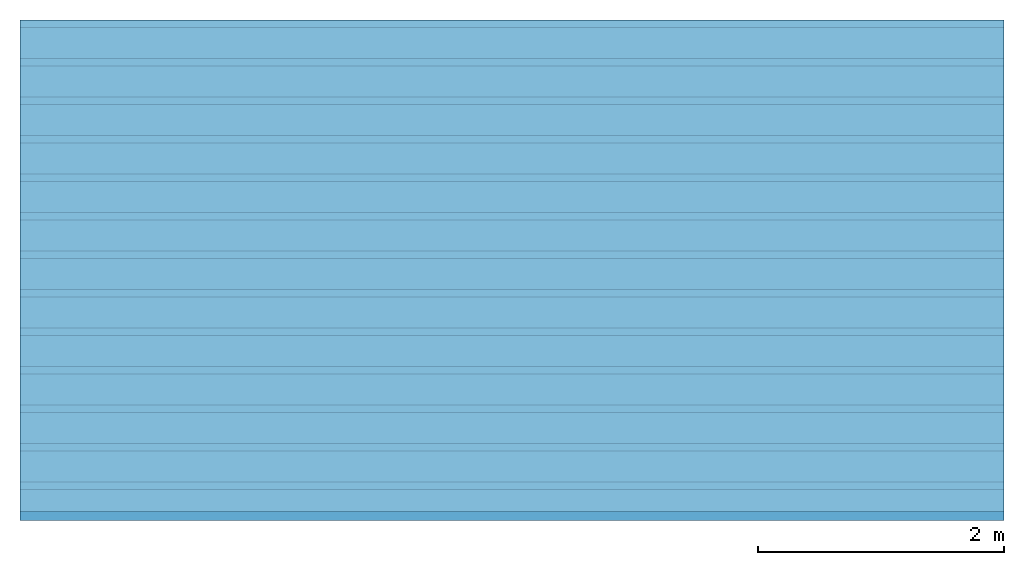
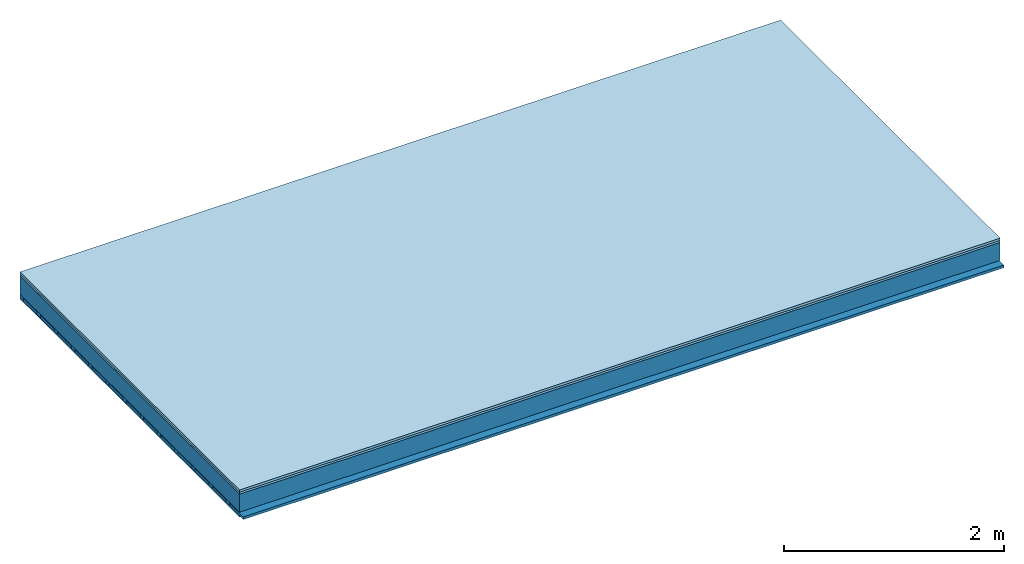
# One storey: 3 members, 3 plates, 1 element without a shape of its own.
"""IFC4 building model written with IfcOpenShell, lengths in metres."""

from ifc_helpers import new_model, si_unit, derived_unit, direction, frame, frame_2d, origin, origin_with_axes, place, context, project, spatial, rectangle, extrude, material, layer, layer_set, type_object, element, aggregate, save


model = new_model("IFC4")

# Units and contexts
plan_context = context("Plan", 3, precision=1e-05, world=origin(), true_north=direction((0.0, 1.0)))
model_context = context("Model", 3, precision=1e-05, world=origin(), true_north=direction((0.0, 1.0)))
ifc_project = project(units=[si_unit("LENGTHUNIT", "METRE"), derived_unit("SOUNDPRESSUREUNIT", [(si_unit("PRESSUREUNIT", "PASCAL", prefix="MICRO"), 0)]), si_unit("ENERGYUNIT", "JOULE", prefix="MEGA"), si_unit("MASSUNIT", "GRAM", prefix="KILO"), derived_unit("THERMALTRANSMITTANCEUNIT", [(si_unit("POWERUNIT", "WATT"), 1), (si_unit("AREAUNIT", "SQUARE_METRE"), -1), (si_unit("THERMODYNAMICTEMPERATUREUNIT", "KELVIN"), -1)]), derived_unit("AREADENSITYUNIT", [(si_unit("MASSUNIT", "GRAM", prefix="KILO"), 1), (si_unit("AREAUNIT", "SQUARE_METRE"), -1)]), derived_unit("USERDEFINED", [(si_unit("ENERGYUNIT", "JOULE", prefix="MEGA"), 1), (si_unit("AREAUNIT", "SQUARE_METRE"), -1)])], contexts=[plan_context, model_context])

# Site, building, storey
site = spatial("IfcSite", under=ifc_project)
building_placement = place(None, origin())
building = spatial("IfcBuilding", under=site, at=building_placement)
storey_placement = place(building_placement, origin())
storey = spatial("IfcBuildingStorey", under=building, at=storey_placement)

# Slab, members, plates
ifc_material_1 = material(Name="Floor heating system Therm38 longitudinal", Category="03.007")
ifc_layer_1 = layer(ifc_material_1, 0.025, Name="On-material")
ifc_material_2 = material(Category="10.009")
ifc_layer_2 = layer(ifc_material_2, 0.022, Name="Impact sound insulation")
ifc_layer_3 = layer(None, 0.2, Name="Supporting structure")
ifc_material_3 = material(Name="of the art")
ifc_layer_4 = layer(ifc_material_3, 0.0, Name="Bond")
ifc_layer_5 = layer(None, 0.04, Name="Battens / profiles")
ifc_material_4 = material(Category="03.007")
ifc_layer_6 = layer(ifc_material_4, 0.015, Name="Ceiling covering 1st layer")
ifc_material_5 = material(Name="Glued joints")
ifc_layer_7 = layer(ifc_material_5, 0.0, Name="Surface / treatment")
ifc_layer_set = layer_set([ifc_layer_1, ifc_layer_2, ifc_layer_3, ifc_layer_4, ifc_layer_5, ifc_layer_6, ifc_layer_7])
slab_type = type_object("IfcSlabType", Name="A0851", PredefinedType="NOTDEFINED", material=ifc_layer_set)
slab_placement = place(None, frame((0.0, 0.0, 0.0), z_axis=(0.0, 0.0, -1.0), x_axis=(1.0, 0.0, 0.0)))
slab = element("IfcSlab", 1, at=slab_placement, inside=storey, type_object=slab_type, material=ifc_layer_set, Name="Slab #1")
ifc_material_6 = material()
member_1_placement = place(slab_placement, origin())
member_1 = element("IfcMember", 2, at=member_1_placement, material=ifc_material_6, Name="Supporting structure", context=plan_context, shape_type="SweptSolid", body=[
    extrude(rectangle(XDim=1.0, YDim=0.2, at=frame_2d((0.5, 0.1), x_axis=(1.0, 0.0))), frame((0.0, 4.0, 0.047), z_axis=(0.0, -1.0, 0.0), x_axis=(1.0, 0.0, 0.0)), (0.0, 0.0, 1.0), 4.0),
    extrude(rectangle(XDim=1.0, YDim=0.2, at=frame_2d((0.5, 0.1), x_axis=(1.0, 0.0))), frame((1.0, 4.0, 0.047), z_axis=(0.0, -1.0, 0.0), x_axis=(1.0, 0.0, 0.0)), (0.0, 0.0, 1.0), 4.0),
    extrude(rectangle(XDim=1.0, YDim=0.2, at=frame_2d((0.5, 0.1), x_axis=(1.0, 0.0))), frame((2.0, 4.0, 0.047), z_axis=(0.0, -1.0, 0.0), x_axis=(1.0, 0.0, 0.0)), (0.0, 0.0, 1.0), 4.0),
    extrude(rectangle(XDim=1.0, YDim=0.2, at=frame_2d((0.5, 0.1), x_axis=(1.0, 0.0))), frame((3.0, 4.0, 0.047), z_axis=(0.0, -1.0, 0.0), x_axis=(1.0, 0.0, 0.0)), (0.0, 0.0, 1.0), 4.0),
    extrude(rectangle(XDim=1.0, YDim=0.2, at=frame_2d((0.5, 0.1), x_axis=(1.0, 0.0))), frame((4.0, 4.0, 0.047), z_axis=(0.0, -1.0, 0.0), x_axis=(1.0, 0.0, 0.0)), (0.0, 0.0, 1.0), 4.0),
    extrude(rectangle(XDim=1.0, YDim=0.2, at=frame_2d((0.5, 0.1), x_axis=(1.0, 0.0))), frame((5.0, 4.0, 0.047), z_axis=(0.0, -1.0, 0.0), x_axis=(1.0, 0.0, 0.0)), (0.0, 0.0, 1.0), 4.0),
    extrude(rectangle(XDim=1.0, YDim=0.2, at=frame_2d((0.5, 0.1), x_axis=(1.0, 0.0))), frame((6.0, 4.0, 0.047), z_axis=(0.0, -1.0, 0.0), x_axis=(1.0, 0.0, 0.0)), (0.0, 0.0, 1.0), 4.0),
    extrude(rectangle(XDim=1.0, YDim=0.2, at=frame_2d((0.5, 0.1), x_axis=(1.0, 0.0))), frame((7.0, 4.0, 0.047), z_axis=(0.0, -1.0, 0.0), x_axis=(1.0, 0.0, 0.0)), (0.0, 0.0, 1.0), 4.0),
])
ifc_material_7 = material()
member_2_placement = place(slab_placement, origin())
member_2 = element("IfcMember", 3, at=member_2_placement, material=ifc_material_7, Name="Battens / profiles", context=plan_context, shape_type="SweptSolid", body=[
    extrude(rectangle(XDim=0.06, YDim=0.04, at=frame_2d((0.03, 0.02), x_axis=(1.0, 0.0))), frame((0.0, 0.0, 0.247), z_axis=(1.0, 0.0, 0.0), x_axis=(0.0, 1.0, 0.0)), (0.0, 0.0, 1.0), 8.0),
    extrude(rectangle(XDim=0.06, YDim=0.04, at=frame_2d((0.03, 0.02), x_axis=(1.0, 0.0))), frame((0.0, 0.313, 0.247), z_axis=(1.0, 0.0, 0.0), x_axis=(0.0, 1.0, 0.0)), (0.0, 0.0, 1.0), 8.0),
    extrude(rectangle(XDim=0.06, YDim=0.04, at=frame_2d((0.03, 0.02), x_axis=(1.0, 0.0))), frame((0.0, 0.626, 0.247), z_axis=(1.0, 0.0, 0.0), x_axis=(0.0, 1.0, 0.0)), (0.0, 0.0, 1.0), 8.0),
    extrude(rectangle(XDim=0.06, YDim=0.04, at=frame_2d((0.03, 0.02), x_axis=(1.0, 0.0))), frame((0.0, 0.939, 0.247), z_axis=(1.0, 0.0, 0.0), x_axis=(0.0, 1.0, 0.0)), (0.0, 0.0, 1.0), 8.0),
    extrude(rectangle(XDim=0.06, YDim=0.04, at=frame_2d((0.03, 0.02), x_axis=(1.0, 0.0))), frame((0.0, 1.252, 0.247), z_axis=(1.0, 0.0, 0.0), x_axis=(0.0, 1.0, 0.0)), (0.0, 0.0, 1.0), 8.0),
    extrude(rectangle(XDim=0.06, YDim=0.04, at=frame_2d((0.03, 0.02), x_axis=(1.0, 0.0))), frame((0.0, 1.565, 0.247), z_axis=(1.0, 0.0, 0.0), x_axis=(0.0, 1.0, 0.0)), (0.0, 0.0, 1.0), 8.0),
    extrude(rectangle(XDim=0.06, YDim=0.04, at=frame_2d((0.03, 0.02), x_axis=(1.0, 0.0))), frame((0.0, 1.878, 0.247), z_axis=(1.0, 0.0, 0.0), x_axis=(0.0, 1.0, 0.0)), (0.0, 0.0, 1.0), 8.0),
    extrude(rectangle(XDim=0.06, YDim=0.04, at=frame_2d((0.03, 0.02), x_axis=(1.0, 0.0))), frame((0.0, 2.191, 0.247), z_axis=(1.0, 0.0, 0.0), x_axis=(0.0, 1.0, 0.0)), (0.0, 0.0, 1.0), 8.0),
    extrude(rectangle(XDim=0.06, YDim=0.04, at=frame_2d((0.03, 0.02), x_axis=(1.0, 0.0))), frame((0.0, 2.504, 0.247), z_axis=(1.0, 0.0, 0.0), x_axis=(0.0, 1.0, 0.0)), (0.0, 0.0, 1.0), 8.0),
    extrude(rectangle(XDim=0.06, YDim=0.04, at=frame_2d((0.03, 0.02), x_axis=(1.0, 0.0))), frame((0.0, 2.817, 0.247), z_axis=(1.0, 0.0, 0.0), x_axis=(0.0, 1.0, 0.0)), (0.0, 0.0, 1.0), 8.0),
    extrude(rectangle(XDim=0.06, YDim=0.04, at=frame_2d((0.03, 0.02), x_axis=(1.0, 0.0))), frame((0.0, 3.13, 0.247), z_axis=(1.0, 0.0, 0.0), x_axis=(0.0, 1.0, 0.0)), (0.0, 0.0, 1.0), 8.0),
    extrude(rectangle(XDim=0.06, YDim=0.04, at=frame_2d((0.03, 0.02), x_axis=(1.0, 0.0))), frame((0.0, 3.443, 0.247), z_axis=(1.0, 0.0, 0.0), x_axis=(0.0, 1.0, 0.0)), (0.0, 0.0, 1.0), 8.0),
    extrude(rectangle(XDim=0.06, YDim=0.04, at=frame_2d((0.03, 0.02), x_axis=(1.0, 0.0))), frame((0.0, 3.756, 0.247), z_axis=(1.0, 0.0, 0.0), x_axis=(0.0, 1.0, 0.0)), (0.0, 0.0, 1.0), 8.0),
])
ifc_material_8 = material()
member_3_placement = place(slab_placement, origin())
member_3 = element("IfcMember", 4, at=member_3_placement, material=ifc_material_8, Name="Cavity", context=plan_context, shape_type="SweptSolid", body=[
    extrude(rectangle(XDim=0.253, YDim=0.03, at=frame_2d((0.1265, 0.015), x_axis=(1.0, 0.0))), frame((0.0, 0.06, 0.257), z_axis=(1.0, 0.0, 0.0), x_axis=(0.0, 1.0, 0.0)), (0.0, 0.0, 1.0), 8.0),
    extrude(rectangle(XDim=0.253, YDim=0.03, at=frame_2d((0.1265, 0.015), x_axis=(1.0, 0.0))), frame((0.0, 0.373, 0.257), z_axis=(1.0, 0.0, 0.0), x_axis=(0.0, 1.0, 0.0)), (0.0, 0.0, 1.0), 8.0),
    extrude(rectangle(XDim=0.253, YDim=0.03, at=frame_2d((0.1265, 0.015), x_axis=(1.0, 0.0))), frame((0.0, 0.686, 0.257), z_axis=(1.0, 0.0, 0.0), x_axis=(0.0, 1.0, 0.0)), (0.0, 0.0, 1.0), 8.0),
    extrude(rectangle(XDim=0.253, YDim=0.03, at=frame_2d((0.1265, 0.015), x_axis=(1.0, 0.0))), frame((0.0, 0.999, 0.257), z_axis=(1.0, 0.0, 0.0), x_axis=(0.0, 1.0, 0.0)), (0.0, 0.0, 1.0), 8.0),
    extrude(rectangle(XDim=0.253, YDim=0.03, at=frame_2d((0.1265, 0.015), x_axis=(1.0, 0.0))), frame((0.0, 1.312, 0.257), z_axis=(1.0, 0.0, 0.0), x_axis=(0.0, 1.0, 0.0)), (0.0, 0.0, 1.0), 8.0),
    extrude(rectangle(XDim=0.253, YDim=0.03, at=frame_2d((0.1265, 0.015), x_axis=(1.0, 0.0))), frame((0.0, 1.625, 0.257), z_axis=(1.0, 0.0, 0.0), x_axis=(0.0, 1.0, 0.0)), (0.0, 0.0, 1.0), 8.0),
    extrude(rectangle(XDim=0.253, YDim=0.03, at=frame_2d((0.1265, 0.015), x_axis=(1.0, 0.0))), frame((0.0, 1.938, 0.257), z_axis=(1.0, 0.0, 0.0), x_axis=(0.0, 1.0, 0.0)), (0.0, 0.0, 1.0), 8.0),
    extrude(rectangle(XDim=0.253, YDim=0.03, at=frame_2d((0.1265, 0.015), x_axis=(1.0, 0.0))), frame((0.0, 2.251, 0.257), z_axis=(1.0, 0.0, 0.0), x_axis=(0.0, 1.0, 0.0)), (0.0, 0.0, 1.0), 8.0),
    extrude(rectangle(XDim=0.253, YDim=0.03, at=frame_2d((0.1265, 0.015), x_axis=(1.0, 0.0))), frame((0.0, 2.564, 0.257), z_axis=(1.0, 0.0, 0.0), x_axis=(0.0, 1.0, 0.0)), (0.0, 0.0, 1.0), 8.0),
    extrude(rectangle(XDim=0.253, YDim=0.03, at=frame_2d((0.1265, 0.015), x_axis=(1.0, 0.0))), frame((0.0, 2.877, 0.257), z_axis=(1.0, 0.0, 0.0), x_axis=(0.0, 1.0, 0.0)), (0.0, 0.0, 1.0), 8.0),
    extrude(rectangle(XDim=0.253, YDim=0.03, at=frame_2d((0.1265, 0.015), x_axis=(1.0, 0.0))), frame((0.0, 3.19, 0.257), z_axis=(1.0, 0.0, 0.0), x_axis=(0.0, 1.0, 0.0)), (0.0, 0.0, 1.0), 8.0),
    extrude(rectangle(XDim=0.253, YDim=0.03, at=frame_2d((0.1265, 0.015), x_axis=(1.0, 0.0))), frame((0.0, 3.503, 0.257), z_axis=(1.0, 0.0, 0.0), x_axis=(0.0, 1.0, 0.0)), (0.0, 0.0, 1.0), 8.0),
    extrude(rectangle(XDim=0.253, YDim=0.03, at=frame_2d((0.1265, 0.015), x_axis=(1.0, 0.0))), frame((0.0, 3.816, 0.257), z_axis=(1.0, 0.0, 0.0), x_axis=(0.0, 1.0, 0.0)), (0.0, 0.0, 1.0), 8.0),
])
plate_1_placement = place(slab_placement, origin())
plate_1 = element("IfcPlate", 5, at=plate_1_placement, material=ifc_material_1, Name="On-material", context=plan_context, shape_type="SweptSolid", body=[
    extrude(rectangle(XDim=8.0, YDim=4.0, at=frame_2d((4.0, 2.0), x_axis=(1.0, 0.0))), origin_with_axes(), (0.0, 0.0, 1.0), 0.025),
])
plate_2_placement = place(slab_placement, origin())
plate_2 = element("IfcPlate", 6, at=plate_2_placement, material=ifc_material_2, Name="Impact sound insulation", context=plan_context, shape_type="SweptSolid", body=[
    extrude(rectangle(XDim=8.0, YDim=4.0, at=frame_2d((4.0, 2.0), x_axis=(1.0, 0.0))), frame((0.0, 0.0, 0.025), z_axis=(0.0, 0.0, 1.0), x_axis=(1.0, 0.0, 0.0)), (0.0, 0.0, 1.0), 0.022),
])
plate_3_placement = place(slab_placement, origin())
plate_3 = element("IfcPlate", 7, at=plate_3_placement, material=ifc_material_4, Name="Ceiling covering 1st layer", context=plan_context, shape_type="SweptSolid", body=[
    extrude(rectangle(XDim=8.0, YDim=4.0, at=frame_2d((4.0, 2.0), x_axis=(1.0, 0.0))), frame((0.0, 0.0, 0.287), z_axis=(0.0, 0.0, 1.0), x_axis=(1.0, 0.0, 0.0)), (0.0, 0.0, 1.0), 0.015),
])
aggregate(slab, [plate_1, plate_2, member_1, member_2, member_3, plate_3])

save(model, "model.ifc")
